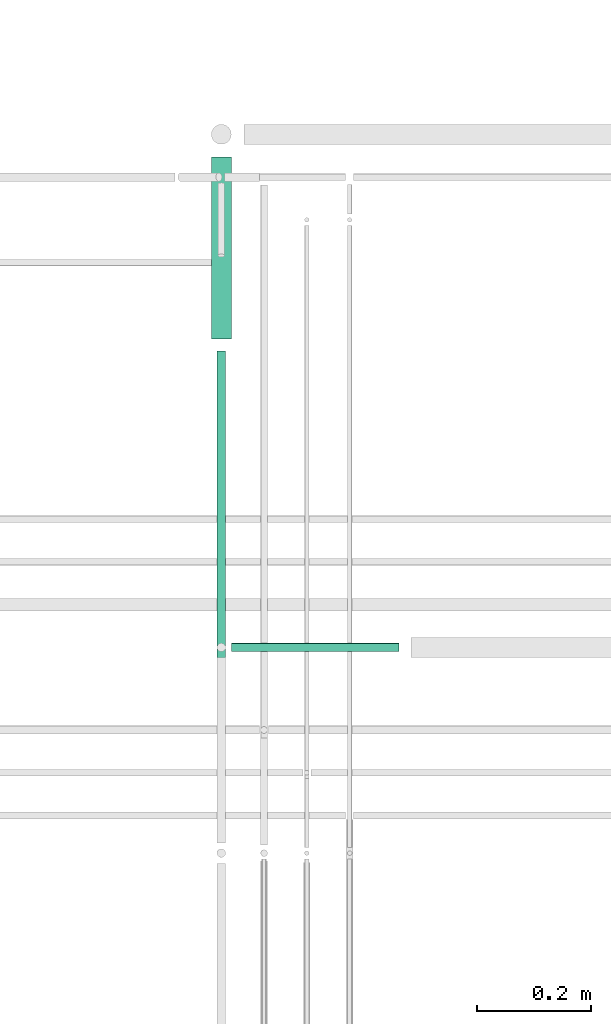
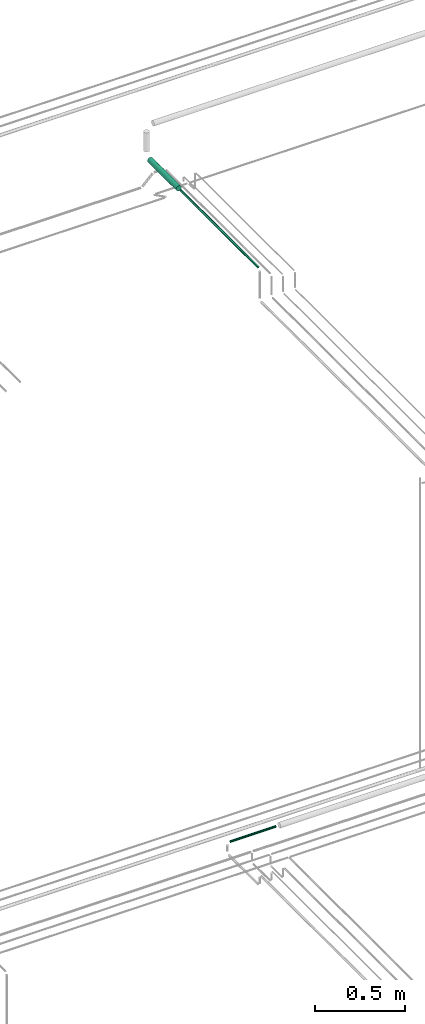
# One storey, part 132 of 331: 3 flow segments.
"""IFC2X3 building model written with IfcOpenShell, lengths in millimetres."""

from ifc_helpers import new_model, entity, si_unit, converted_unit, derived_unit, direction, frame, frame_2d, origin, origin_2d_with_axis, place, context, subcontext, project, spatial, circle, extrude, type_object, element, save


model = new_model("IFC2X3")

# Units and contexts
model_context = context("Model", 3, precision=0.01, world=origin(), true_north=direction((6.12303176911189e-17, 1.0)))
body_context = subcontext(model_context, "Body", "Model", "MODEL_VIEW")
ifc_project = project(units=[si_unit("LENGTHUNIT", "METRE", prefix="MILLI"), si_unit("AREAUNIT", "SQUARE_METRE"), si_unit("VOLUMEUNIT", "CUBIC_METRE"), converted_unit("PLANEANGLEUNIT", "DEGREE", entity("IfcRatioMeasure", 0.0174532925199433), si_unit("PLANEANGLEUNIT", "RADIAN"), dimensions=[0, 0, 0, 0, 0, 0, 0]), si_unit("MASSUNIT", "GRAM", prefix="KILO"), derived_unit("MASSDENSITYUNIT", [(si_unit("MASSUNIT", "GRAM", prefix="KILO"), 1), (si_unit("LENGTHUNIT", "METRE"), -3)]), derived_unit("MOMENTOFINERTIAUNIT", [(si_unit("LENGTHUNIT", "METRE"), 4)]), si_unit("TIMEUNIT", "SECOND"), si_unit("FREQUENCYUNIT", "HERTZ"), si_unit("THERMODYNAMICTEMPERATUREUNIT", "DEGREE_CELSIUS"), derived_unit("THERMALTRANSMITTANCEUNIT", [(si_unit("MASSUNIT", "GRAM", prefix="KILO"), 1), (si_unit("THERMODYNAMICTEMPERATUREUNIT", "KELVIN"), -1), (si_unit("TIMEUNIT", "SECOND"), -3)]), derived_unit("VOLUMETRICFLOWRATEUNIT", [(si_unit("LENGTHUNIT", "METRE"), 3), (si_unit("TIMEUNIT", "SECOND"), -1)]), derived_unit("MASSFLOWRATEUNIT", [(si_unit("MASSUNIT", "GRAM", prefix="KILO"), 1), (si_unit("TIMEUNIT", "SECOND"), -1)]), derived_unit("ROTATIONALFREQUENCYUNIT", [(si_unit("TIMEUNIT", "SECOND"), -1)]), si_unit("ELECTRICCURRENTUNIT", "AMPERE"), si_unit("ELECTRICVOLTAGEUNIT", "VOLT"), si_unit("POWERUNIT", "WATT"), si_unit("FORCEUNIT", "NEWTON", prefix="KILO"), si_unit("ILLUMINANCEUNIT", "LUX"), si_unit("LUMINOUSFLUXUNIT", "LUMEN"), si_unit("LUMINOUSINTENSITYUNIT", "CANDELA"), derived_unit("USERDEFINED", [(si_unit("MASSUNIT", "GRAM", prefix="KILO"), -1), (si_unit("LENGTHUNIT", "METRE"), -2), (si_unit("TIMEUNIT", "SECOND"), 3), (si_unit("LUMINOUSFLUXUNIT", "LUMEN"), 1)]), derived_unit("LINEARVELOCITYUNIT", [(si_unit("LENGTHUNIT", "METRE"), 1), (si_unit("TIMEUNIT", "SECOND"), -1)]), si_unit("PRESSUREUNIT", "PASCAL"), derived_unit("USERDEFINED", [(si_unit("LENGTHUNIT", "METRE"), -2), (si_unit("MASSUNIT", "GRAM", prefix="KILO"), 1), (si_unit("TIMEUNIT", "SECOND"), -2)]), derived_unit("LINEARFORCEUNIT", [(si_unit("MASSUNIT", "GRAM", prefix="KILO"), 1), (si_unit("LENGTHUNIT", "METRE"), 1), (si_unit("TIMEUNIT", "SECOND"), -2), (si_unit("LENGTHUNIT", "METRE"), -1)]), derived_unit("PLANARFORCEUNIT", [(si_unit("MASSUNIT", "GRAM", prefix="KILO"), 1), (si_unit("LENGTHUNIT", "METRE"), 1), (si_unit("TIMEUNIT", "SECOND"), -2), (si_unit("LENGTHUNIT", "METRE"), -2)])], contexts=[model_context])

# Site, building, storey
site_placement = place(None, frame((0.0, -0.00077364408347762, 0.0)))
site = spatial("IfcSite", under=ifc_project, at=site_placement, CompositionType="ELEMENT")
building_placement = place(site_placement, origin())
building = spatial("IfcBuilding", under=site, at=building_placement, CompositionType="ELEMENT")
storey_placement = place(building_placement, origin())
storey = spatial("IfcBuildingStorey", under=building, at=storey_placement, CompositionType="ELEMENT", Elevation=0.0)

# Flow segments
pipe_segment_type = type_object("IfcPipeSegmentType", PredefinedType="NOTDEFINED")
flow_segment_1_placement = place(storey_placement, frame((20639.1085349484, 8441.52529159143, 14540.904727764)))
element("IfcFlowSegment", 1, at=flow_segment_1_placement, inside=storey, type_object=pipe_segment_type, context=body_context, shape_type="SweptSolid", body=[
    extrude(circle(Radius=7.5, at=frame_2d((1.08286712929839e-11, 2.16573425859679e-12), x_axis=(1.0, 0.0))), frame((0.0, 9.09527223592719, 9.09527223591419), z_axis=(1.0, 0.0, 0.0), x_axis=(0.0, 1.0, 0.0)), (0.0, 0.0, 1.0), 294.003348329238),
])
flow_segment_2_placement = place(storey_placement, frame((20612.233655358, 8108.14880665485, 18655.9047277641)))
element("IfcFlowSegment", 2, at=flow_segment_2_placement, inside=storey, type_object=pipe_segment_type, context=body_context, shape_type="SweptSolid", body=[
    extrude(circle(Radius=7.5, at=origin_2d_with_axis()), frame((9.09527223593152, 0.0, 9.09527223591636), z_axis=(0.0, 1.0, 0.0), x_axis=(1.0, 0.0, 0.0)), (0.0, 0.0, 1.0), 861.851193345117),
])
flow_segment_3_placement = place(building_placement, frame((20602.233655358, 8991.0, 18645.9047277641)))
element("IfcFlowSegment", 3, at=flow_segment_3_placement, inside=storey, type_object=pipe_segment_type, context=body_context, shape_type="SweptSolid", body=[
    extrude(circle(Radius=17.5, at=frame_2d((-7.65023969506729e-08, 0.0), x_axis=(1.0, 0.0))), frame((19.0952723124187, 8.39438598632114e-09, 19.0952722359163), z_axis=(0.0, 1.0, 0.0), x_axis=(-1.0, 0.0, 0.0)), (0.0, 0.0, 1.0), 319.000000000246),
])

save(model, "model.ifc")
